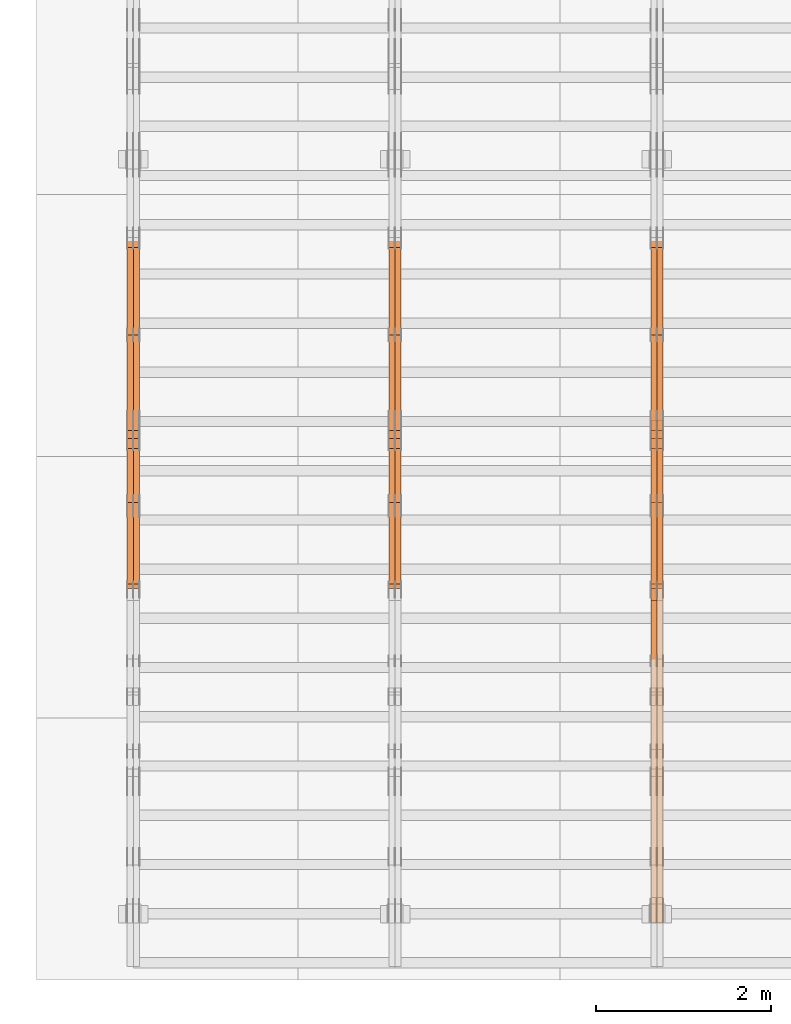
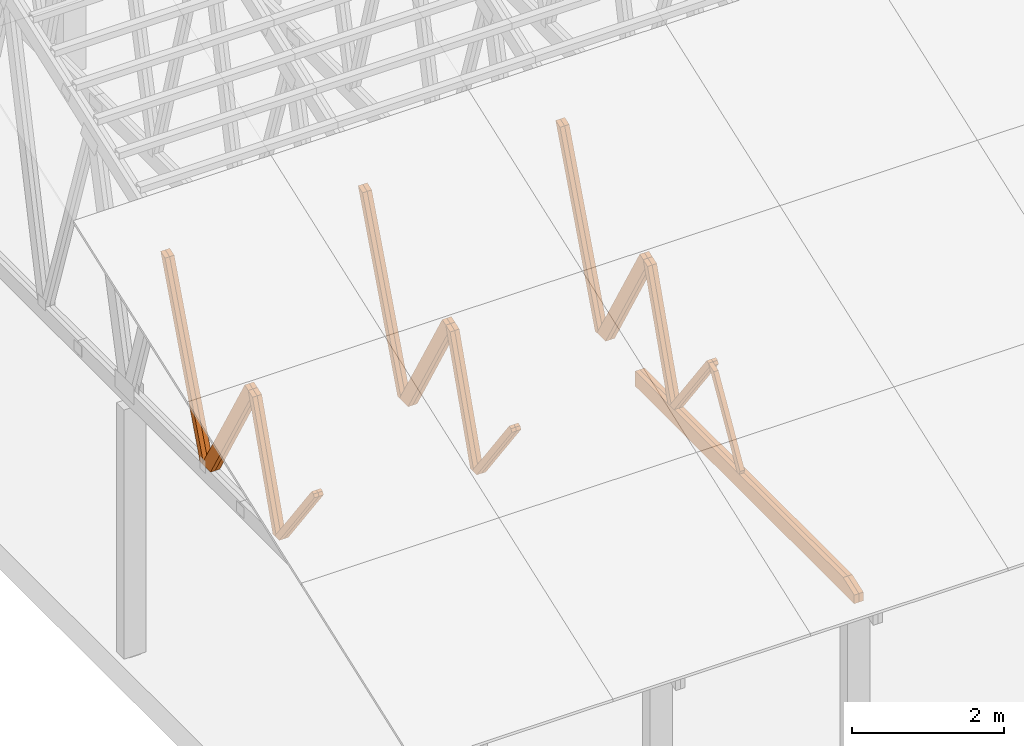
# One storey, part 13 of 189: 27 proxies.
"""IFC2X3 building model written with IfcOpenShell, lengths in millimetres."""

from ifc_helpers import new_model, entity, si_unit, converted_unit, derived_unit, direction, frame, origin, place, context, subcontext, project, spatial, polyline, outline, extrude, source, transform, mapped, material, type_object, type_shapes, element, save


model = new_model("IFC2X3")

# Units and contexts
model_context = context("Model", 3, precision=0.01, world=origin(), true_north=direction((6.12303176911189e-17, 1.0)))
body_context = subcontext(model_context, "Body", "Model", "MODEL_VIEW")
ifc_project = project(units=[si_unit("LENGTHUNIT", "METRE", prefix="MILLI"), si_unit("AREAUNIT", "SQUARE_METRE"), si_unit("VOLUMEUNIT", "CUBIC_METRE"), converted_unit("PLANEANGLEUNIT", "DEGREE", entity("IfcRatioMeasure", 0.0174532925199433), si_unit("PLANEANGLEUNIT", "RADIAN"), dimensions=[0, 0, 0, 0, 0, 0, 0]), si_unit("MASSUNIT", "GRAM", prefix="KILO"), derived_unit("MASSDENSITYUNIT", [(si_unit("MASSUNIT", "GRAM", prefix="KILO"), 1), (si_unit("LENGTHUNIT", "METRE"), -3)]), si_unit("TIMEUNIT", "SECOND"), si_unit("FREQUENCYUNIT", "HERTZ"), si_unit("THERMODYNAMICTEMPERATUREUNIT", "DEGREE_CELSIUS"), derived_unit("THERMALTRANSMITTANCEUNIT", [(si_unit("MASSUNIT", "GRAM", prefix="KILO"), 1), (si_unit("THERMODYNAMICTEMPERATUREUNIT", "KELVIN"), -1), (si_unit("TIMEUNIT", "SECOND"), -3)]), derived_unit("VOLUMETRICFLOWRATEUNIT", [(si_unit("LENGTHUNIT", "METRE"), 3), (si_unit("TIMEUNIT", "SECOND"), -1)]), si_unit("ELECTRICCURRENTUNIT", "AMPERE"), si_unit("ELECTRICVOLTAGEUNIT", "VOLT"), si_unit("POWERUNIT", "WATT"), si_unit("FORCEUNIT", "NEWTON"), si_unit("ILLUMINANCEUNIT", "LUX"), si_unit("LUMINOUSFLUXUNIT", "LUMEN"), si_unit("LUMINOUSINTENSITYUNIT", "CANDELA"), derived_unit("USERDEFINED", [(si_unit("MASSUNIT", "GRAM", prefix="KILO"), -1), (si_unit("LENGTHUNIT", "METRE"), -2), (si_unit("TIMEUNIT", "SECOND"), 3), (si_unit("LUMINOUSFLUXUNIT", "LUMEN"), 1)]), derived_unit("LINEARVELOCITYUNIT", [(si_unit("LENGTHUNIT", "METRE"), 1), (si_unit("TIMEUNIT", "SECOND"), -1)]), si_unit("PRESSUREUNIT", "PASCAL"), derived_unit("USERDEFINED", [(si_unit("LENGTHUNIT", "METRE"), -2), (si_unit("MASSUNIT", "GRAM", prefix="KILO"), 1), (si_unit("TIMEUNIT", "SECOND"), -2)])], contexts=[model_context])

# Site, building, storey
site_placement = place(None, origin())
site = spatial("IfcSite", under=ifc_project, at=site_placement, CompositionType="ELEMENT")
building_placement = place(site_placement, origin())
building = spatial("IfcBuilding", under=site, at=building_placement, CompositionType="ELEMENT")
storey_placement = place(building_placement, origin())
storey = spatial("IfcBuildingStorey", under=building, at=storey_placement, Name="Default", CompositionType="ELEMENT", Elevation=0.0)

# Proxies
ifc_material_1 = material(Name="IfcSurfaceStyle #35470")
building_element_proxy_type_1 = type_object("IfcBuildingElementProxyType", Name="T1-W8 35468", PredefinedType="NOTDEFINED", material=ifc_material_1)
shared_shape_1 = source(origin(), body_context, "Body", "SweptSolid", [
    extrude(outline(polyline([(-1781.70529904483, -47.500320228718), (1161.65050357787, -47.5003202287179), (1179.56135870849, 0.000731866266039397), (1140.6022069428, 47.4998218997103), (-1700.10877018433, 47.5000866914596), (-1781.70529904483, -47.500320228718)])), frame((1179.56135870869, 47.5007236522113, 0.0), z_axis=(0.0, 0.0, 1.0), x_axis=(-1.0, 3.74658825645258e-07, 0.0)), (0.0, 0.0, 1.0), 69.9999999999998),
])
type_shapes(building_element_proxy_type_1, [shared_shape_1])
proxy_1_placement = place(building_placement, frame((6335.0, 6723.5697965901, 261.758864533503), z_axis=(-1.0, 0.0, 0.0), x_axis=(0.0, 0.352814979177603, 0.93569310698963)))
element("IfcBuildingElementProxy", 1, at=proxy_1_placement, inside=storey, type_object=building_element_proxy_type_1, material=ifc_material_1, Name="T1-W8", context=body_context, shape_type="MappedRepresentation", body=[
    mapped(shared_shape_1, transform((0.0, 0.0, 0.0), scale=1.0)),
])
ifc_material_2 = material(Name="IfcSurfaceStyle #35404")
building_element_proxy_type_2 = type_object("IfcBuildingElementProxyType", Name="T1-W8 35402", PredefinedType="NOTDEFINED", material=ifc_material_2)
shared_shape_2 = source(origin(), body_context, "Body", "SweptSolid", [
    extrude(outline(polyline([(-1781.70529904483, -47.500320228718), (1161.65050357787, -47.5003202287179), (1179.56135870849, 0.000731866266039397), (1140.6022069428, 47.4998218997103), (-1700.10877018433, 47.5000866914596), (-1781.70529904483, -47.500320228718)])), frame((1179.56135870869, 47.5007236522113, 0.0), z_axis=(0.0, 0.0, 1.0), x_axis=(-1.0, 3.74658825645258e-07, 0.0)), (0.0, 0.0, 1.0), 69.9999999999998),
])
type_shapes(building_element_proxy_type_2, [shared_shape_2])
proxy_2_placement = place(building_placement, frame((6265.0, 6723.5697965901, 261.758864533503), z_axis=(-1.0, 0.0, 0.0), x_axis=(0.0, 0.352814979177603, 0.93569310698963)))
element("IfcBuildingElementProxy", 2, at=proxy_2_placement, inside=storey, type_object=building_element_proxy_type_2, material=ifc_material_2, Name="T1-W8", context=body_context, shape_type="MappedRepresentation", body=[
    mapped(shared_shape_2, transform((0.0, 0.0, 0.0), scale=1.0)),
])
ifc_material_3 = material(Name="IfcSurfaceStyle #35206")
building_element_proxy_type_3 = type_object("IfcBuildingElementProxyType", Name="T1-W2 35204", PredefinedType="NOTDEFINED", material=ifc_material_3)
shared_shape_3 = source(origin(), body_context, "Body", "SweptSolid", [
    extrude(outline(polyline([(-765.033104991319, -1130.91940266317), (-539.905732758898, -1130.91940266317), (493.678280567457, 660.584515081422), (452.144945212405, 783.697385511457), (359.115611970356, 817.556904733455), (-765.033104991319, -1130.91940266317)])), frame((904.774360566371, 97.5002668805543, 0.0), z_axis=(0.0, 0.0, 1.0), x_axis=(-0.499731715721184, 0.866180242387438, 0.0)), (0.0, 0.0, 1.0), 69.9999999999998),
])
type_shapes(building_element_proxy_type_3, [shared_shape_3])
proxy_3_placement = place(building_placement, frame((6335.0, 5635.28919163287, 2208.3400784451), z_axis=(-1.0, 0.0, 0.0), x_axis=(0.0, 0.5, -0.866025403784439)))
element("IfcBuildingElementProxy", 3, at=proxy_3_placement, inside=storey, type_object=building_element_proxy_type_3, material=ifc_material_3, Name="T1-W2", context=body_context, shape_type="MappedRepresentation", body=[
    mapped(shared_shape_3, transform((0.0, 0.0, 0.0), scale=1.0)),
])
ifc_material_4 = material(Name="IfcSurfaceStyle #35140")
building_element_proxy_type_4 = type_object("IfcBuildingElementProxyType", Name="T1-W2 35138", PredefinedType="NOTDEFINED", material=ifc_material_4)
shared_shape_4 = source(origin(), body_context, "Body", "SweptSolid", [
    extrude(outline(polyline([(-765.033104991319, -1130.91940266317), (-539.905732758898, -1130.91940266317), (493.678280567457, 660.584515081422), (452.144945212405, 783.697385511457), (359.115611970356, 817.556904733455), (-765.033104991319, -1130.91940266317)])), frame((904.774360566371, 97.5002668805543, 0.0), z_axis=(0.0, 0.0, 1.0), x_axis=(-0.499731715721184, 0.866180242387438, 0.0)), (0.0, 0.0, 1.0), 69.9999999999998),
])
type_shapes(building_element_proxy_type_4, [shared_shape_4])
proxy_4_placement = place(building_placement, frame((6265.0, 5635.28919163287, 2208.3400784451), z_axis=(-1.0, 0.0, 0.0), x_axis=(0.0, 0.5, -0.866025403784439)))
element("IfcBuildingElementProxy", 4, at=proxy_4_placement, inside=storey, type_object=building_element_proxy_type_4, material=ifc_material_4, Name="T1-W2", context=body_context, shape_type="MappedRepresentation", body=[
    mapped(shared_shape_4, transform((0.0, 0.0, 0.0), scale=1.0)),
])
ifc_material_5 = material(Name="IfcSurfaceStyle #34942")
building_element_proxy_type_5 = type_object("IfcBuildingElementProxyType", Name="T1-W9 34940", PredefinedType="NOTDEFINED", material=ifc_material_5)
shared_shape_5 = source(origin(), body_context, "Body", "SweptSolid", [
    extrude(outline(polyline([(-1227.3969292634, -47.5000382896404), (793.242467803064, -47.5000382896404), (809.267705296822, 1.0956605530188e-05), (776.329919980315, 47.5000328113376), (-1151.4431638168, 47.5000328113376), (-1227.3969292634, -47.5000382896404)])), frame((809.267705296822, 47.5000328113376, 0.0), z_axis=(0.0, 0.0, 1.0), x_axis=(-1.0, 0.0, 0.0)), (0.0, 0.0, 1.0), 69.9999999999999),
])
type_shapes(building_element_proxy_type_5, [shared_shape_5])
proxy_5_placement = place(building_placement, frame((6335.0, 4809.76380889125, 260.184242613649), z_axis=(-1.0, 0.0, 0.0), x_axis=(0.0, 0.31966811847134, 0.947529574226047)))
element("IfcBuildingElementProxy", 5, at=proxy_5_placement, inside=storey, type_object=building_element_proxy_type_5, material=ifc_material_5, Name="T1-W9", context=body_context, shape_type="MappedRepresentation", body=[
    mapped(shared_shape_5, transform((0.0, 0.0, 0.0), scale=1.0)),
])
ifc_material_6 = material(Name="IfcSurfaceStyle #34876")
building_element_proxy_type_6 = type_object("IfcBuildingElementProxyType", Name="T1-W9 34874", PredefinedType="NOTDEFINED", material=ifc_material_6)
shared_shape_6 = source(origin(), body_context, "Body", "SweptSolid", [
    extrude(outline(polyline([(-1227.3969292634, -47.5000382896404), (793.242467803064, -47.5000382896404), (809.267705296822, 1.0956605530188e-05), (776.329919980315, 47.5000328113376), (-1151.4431638168, 47.5000328113376), (-1227.3969292634, -47.5000382896404)])), frame((809.267705296822, 47.5000328113376, 0.0), z_axis=(0.0, 0.0, 1.0), x_axis=(-1.0, 0.0, 0.0)), (0.0, 0.0, 1.0), 69.9999999999999),
])
type_shapes(building_element_proxy_type_6, [shared_shape_6])
proxy_6_placement = place(building_placement, frame((6265.0, 4809.76380889125, 260.184242613649), z_axis=(-1.0, 0.0, 0.0), x_axis=(0.0, 0.31966811847134, 0.947529574226047)))
element("IfcBuildingElementProxy", 6, at=proxy_6_placement, inside=storey, type_object=building_element_proxy_type_6, material=ifc_material_6, Name="T1-W9", context=body_context, shape_type="MappedRepresentation", body=[
    mapped(shared_shape_6, transform((0.0, 0.0, 0.0), scale=1.0)),
])
ifc_material_7 = material(Name="IfcSurfaceStyle #34678")
building_element_proxy_type_7 = type_object("IfcBuildingElementProxyType", Name="T1-W10 34676", PredefinedType="NOTDEFINED", material=ifc_material_7)
shared_shape_7 = source(origin(), body_context, "Body", "SweptSolid", [
    extrude(outline(polyline([(-922.639472665691, -47.5001890573134), (629.920966338637, -47.5001890573134), (650.067737483374, 0.000694680531158376), (635.89112756682, 47.4998417170478), (-993.240358723139, 47.4998417170478), (-922.639472665691, -47.5001890573134)])), frame((650.068202545693, 47.4999816623145, 0.0), z_axis=(0.0, 0.0, 1.0), x_axis=(-1.0, 0.0, 0.0)), (0.0, 0.0, 1.0), 69.9999999999999),
])
type_shapes(building_element_proxy_type_7, [shared_shape_7])
proxy_7_placement = place(building_placement, frame((6335.0, 3874.56126239818, 1563.95828147518), z_axis=(-1.0, 0.0, 0.0), x_axis=(0.0, 0.596486092002, -0.802623412347398)))
element("IfcBuildingElementProxy", 7, at=proxy_7_placement, inside=storey, type_object=building_element_proxy_type_7, material=ifc_material_7, Name="T1-W10", context=body_context, shape_type="MappedRepresentation", body=[
    mapped(shared_shape_7, transform((0.0, 0.0, 0.0), scale=1.0)),
])
ifc_material_8 = material(Name="IfcSurfaceStyle #34612")
building_element_proxy_type_8 = type_object("IfcBuildingElementProxyType", Name="T1-W10 34610", PredefinedType="NOTDEFINED", material=ifc_material_8)
shared_shape_8 = source(origin(), body_context, "Body", "SweptSolid", [
    extrude(outline(polyline([(-922.639472665691, -47.5001890573134), (629.920966338637, -47.5001890573134), (650.067737483374, 0.000694680531158376), (635.89112756682, 47.4998417170478), (-993.240358723139, 47.4998417170478), (-922.639472665691, -47.5001890573134)])), frame((650.068202545693, 47.4999816623145, 0.0), z_axis=(0.0, 0.0, 1.0), x_axis=(-1.0, 0.0, 0.0)), (0.0, 0.0, 1.0), 69.9999999999999),
])
type_shapes(building_element_proxy_type_8, [shared_shape_8])
proxy_8_placement = place(building_placement, frame((6265.0, 3874.56126239818, 1563.95828147518), z_axis=(-1.0, 0.0, 0.0), x_axis=(0.0, 0.596486092002, -0.802623412347398)))
element("IfcBuildingElementProxy", 8, at=proxy_8_placement, inside=storey, type_object=building_element_proxy_type_8, material=ifc_material_8, Name="T1-W10", context=body_context, shape_type="MappedRepresentation", body=[
    mapped(shared_shape_8, transform((0.0, 0.0, 0.0), scale=1.0)),
])
ifc_material_9 = material(Name="IfcSurfaceStyle #34348")
building_element_proxy_type_9 = type_object("IfcBuildingElementProxyType", Name="T1-W11 34346", PredefinedType="NOTDEFINED", material=ifc_material_9)
shared_shape_9 = source(origin(), body_context, "Body", "SweptSolid", [
    extrude(outline(polyline([(593.358012843793, -552.565239103314), (742.388662259985, -552.565239103314), (-410.498749190676, 401.275038694583), (-462.246133468927, 382.44069706518), (-463.001792444175, 321.414742446865), (593.358012843793, -552.565239103314)])), frame((599.94412413079, 47.5003788877286, 0.0), z_axis=(0.0, 0.0, 1.0), x_axis=(0.770483455324544, 0.637459994879013, 0.0)), (0.0, 0.0, 1.0), 69.9999999999999),
])
type_shapes(building_element_proxy_type_9, [shared_shape_9])
proxy_9_placement = place(building_placement, frame((6265.0, 2983.26655629375, 269.034992751429), z_axis=(-1.0, 0.0, 0.0), x_axis=(0.0, 0.505995901100606, 0.862535882192379)))
element("IfcBuildingElementProxy", 9, at=proxy_9_placement, inside=storey, type_object=building_element_proxy_type_9, material=ifc_material_9, Name="T1-W11", context=body_context, shape_type="MappedRepresentation", body=[
    mapped(shared_shape_9, transform((0.0, 0.0, 0.0), scale=1.0)),
])
ifc_material_10 = material(Name="IfcSurfaceStyle #32542")
building_element_proxy_type_10 = type_object("IfcBuildingElementProxyType", Name="T1-B2 32540", PredefinedType="NOTDEFINED", material=ifc_material_10)
shared_shape_10 = source(origin(), body_context, "Body", "SweptSolid", [
    extrude(outline(polyline([(-3399.385546875, -125.855288696291), (2363.08125, -125.855288696291), (2363.08125, 13.4211547851572), (2072.60859375, 119.144711303712), (-3399.385546875, 119.144711303712), (-3399.385546875, -125.855288696291)])), frame((2363.08125, 119.144711303712, 0.0), z_axis=(0.0, 0.0, 1.0), x_axis=(-1.0, 0.0, 0.0)), (0.0, 0.0, 1.0), 69.9999999999997),
])
type_shapes(building_element_proxy_type_10, [shared_shape_10])
proxy_10_placement = place(building_placement, frame((6335.0, 0.0, 245.0), z_axis=(-1.0, 0.0, 0.0), x_axis=(0.0, 1.0, 0.0)))
element("IfcBuildingElementProxy", 10, at=proxy_10_placement, inside=storey, type_object=building_element_proxy_type_10, material=ifc_material_10, Name="T1-B2", context=body_context, shape_type="MappedRepresentation", body=[
    mapped(shared_shape_10, transform((0.0, 0.0, 0.0), scale=1.0)),
])
ifc_material_11 = material(Name="IfcSurfaceStyle #32476")
building_element_proxy_type_11 = type_object("IfcBuildingElementProxyType", Name="T1-B2 32474", PredefinedType="NOTDEFINED", material=ifc_material_11)
shared_shape_11 = source(origin(), body_context, "Body", "SweptSolid", [
    extrude(outline(polyline([(-3399.385546875, -125.855288696291), (2363.08125, -125.855288696291), (2363.08125, 13.4211547851572), (2072.60859375, 119.144711303712), (-3399.385546875, 119.144711303712), (-3399.385546875, -125.855288696291)])), frame((2363.08125, 119.144711303712, 0.0), z_axis=(0.0, 0.0, 1.0), x_axis=(-1.0, 0.0, 0.0)), (0.0, 0.0, 1.0), 69.9999999999997),
])
type_shapes(building_element_proxy_type_11, [shared_shape_11])
proxy_11_placement = place(building_placement, frame((6265.0, 0.0, 245.0), z_axis=(-1.0, 0.0, 0.0), x_axis=(0.0, 1.0, 0.0)))
element("IfcBuildingElementProxy", 11, at=proxy_11_placement, inside=storey, type_object=building_element_proxy_type_11, material=ifc_material_11, Name="T1-B2", context=body_context, shape_type="MappedRepresentation", body=[
    mapped(shared_shape_11, transform((0.0, 0.0, 0.0), scale=1.0)),
])
ifc_material_12 = material(Name="IfcSurfaceStyle #19680")
building_element_proxy_type_12 = type_object("IfcBuildingElementProxyType", Name="T1-W8 19678", PredefinedType="NOTDEFINED", material=ifc_material_12)
shared_shape_12 = source(origin(), body_context, "Body", "SweptSolid", [
    extrude(outline(polyline([(-1781.70529904483, -47.500320228718), (1161.65050357787, -47.5003202287179), (1179.56135870849, 0.000731866266039397), (1140.6022069428, 47.4998218997103), (-1700.10877018433, 47.5000866914596), (-1781.70529904483, -47.500320228718)])), frame((1179.56135870869, 47.5007236522113, 0.0), z_axis=(0.0, 0.0, 1.0), x_axis=(-1.0, 3.74658825645258e-07, 0.0)), (0.0, 0.0, 1.0), 69.9999999999998),
])
type_shapes(building_element_proxy_type_12, [shared_shape_12])
proxy_12_placement = place(building_placement, frame((3335.0, 6723.5697965901, 261.758864533503), z_axis=(-1.0, 0.0, 0.0), x_axis=(0.0, 0.352814979177603, 0.93569310698963)))
element("IfcBuildingElementProxy", 12, at=proxy_12_placement, inside=storey, type_object=building_element_proxy_type_12, material=ifc_material_12, Name="T1-W8", context=body_context, shape_type="MappedRepresentation", body=[
    mapped(shared_shape_12, transform((0.0, 0.0, 0.0), scale=1.0)),
])
ifc_material_13 = material(Name="IfcSurfaceStyle #19614")
building_element_proxy_type_13 = type_object("IfcBuildingElementProxyType", Name="T1-W8 19612", PredefinedType="NOTDEFINED", material=ifc_material_13)
shared_shape_13 = source(origin(), body_context, "Body", "SweptSolid", [
    extrude(outline(polyline([(-1781.70529904483, -47.500320228718), (1161.65050357787, -47.5003202287179), (1179.56135870849, 0.000731866266039397), (1140.6022069428, 47.4998218997103), (-1700.10877018433, 47.5000866914596), (-1781.70529904483, -47.500320228718)])), frame((1179.56135870869, 47.5007236522113, 0.0), z_axis=(0.0, 0.0, 1.0), x_axis=(-1.0, 3.74658825645258e-07, 0.0)), (0.0, 0.0, 1.0), 69.9999999999998),
])
type_shapes(building_element_proxy_type_13, [shared_shape_13])
proxy_13_placement = place(building_placement, frame((3265.0, 6723.5697965901, 261.758864533503), z_axis=(-1.0, 0.0, 0.0), x_axis=(0.0, 0.352814979177603, 0.93569310698963)))
element("IfcBuildingElementProxy", 13, at=proxy_13_placement, inside=storey, type_object=building_element_proxy_type_13, material=ifc_material_13, Name="T1-W8", context=body_context, shape_type="MappedRepresentation", body=[
    mapped(shared_shape_13, transform((0.0, 0.0, 0.0), scale=1.0)),
])
ifc_material_14 = material(Name="IfcSurfaceStyle #19416")
building_element_proxy_type_14 = type_object("IfcBuildingElementProxyType", Name="T1-W2 19414", PredefinedType="NOTDEFINED", material=ifc_material_14)
shared_shape_14 = source(origin(), body_context, "Body", "SweptSolid", [
    extrude(outline(polyline([(-765.033104991319, -1130.91940266317), (-539.905732758898, -1130.91940266317), (493.678280567457, 660.584515081422), (452.144945212405, 783.697385511457), (359.115611970356, 817.556904733455), (-765.033104991319, -1130.91940266317)])), frame((904.774360566371, 97.5002668805543, 0.0), z_axis=(0.0, 0.0, 1.0), x_axis=(-0.499731715721184, 0.866180242387438, 0.0)), (0.0, 0.0, 1.0), 69.9999999999998),
])
type_shapes(building_element_proxy_type_14, [shared_shape_14])
proxy_14_placement = place(building_placement, frame((3335.0, 5635.28919163287, 2208.3400784451), z_axis=(-1.0, 0.0, 0.0), x_axis=(0.0, 0.5, -0.866025403784439)))
element("IfcBuildingElementProxy", 14, at=proxy_14_placement, inside=storey, type_object=building_element_proxy_type_14, material=ifc_material_14, Name="T1-W2", context=body_context, shape_type="MappedRepresentation", body=[
    mapped(shared_shape_14, transform((0.0, 0.0, 0.0), scale=1.0)),
])
ifc_material_15 = material(Name="IfcSurfaceStyle #19350")
building_element_proxy_type_15 = type_object("IfcBuildingElementProxyType", Name="T1-W2 19348", PredefinedType="NOTDEFINED", material=ifc_material_15)
shared_shape_15 = source(origin(), body_context, "Body", "SweptSolid", [
    extrude(outline(polyline([(-765.033104991319, -1130.91940266317), (-539.905732758898, -1130.91940266317), (493.678280567457, 660.584515081422), (452.144945212405, 783.697385511457), (359.115611970356, 817.556904733455), (-765.033104991319, -1130.91940266317)])), frame((904.774360566371, 97.5002668805543, 0.0), z_axis=(0.0, 0.0, 1.0), x_axis=(-0.499731715721184, 0.866180242387438, 0.0)), (0.0, 0.0, 1.0), 69.9999999999998),
])
type_shapes(building_element_proxy_type_15, [shared_shape_15])
proxy_15_placement = place(building_placement, frame((3265.0, 5635.28919163287, 2208.3400784451), z_axis=(-1.0, 0.0, 0.0), x_axis=(0.0, 0.5, -0.866025403784439)))
element("IfcBuildingElementProxy", 15, at=proxy_15_placement, inside=storey, type_object=building_element_proxy_type_15, material=ifc_material_15, Name="T1-W2", context=body_context, shape_type="MappedRepresentation", body=[
    mapped(shared_shape_15, transform((0.0, 0.0, 0.0), scale=1.0)),
])
ifc_material_16 = material(Name="IfcSurfaceStyle #19152")
building_element_proxy_type_16 = type_object("IfcBuildingElementProxyType", Name="T1-W9 19150", PredefinedType="NOTDEFINED", material=ifc_material_16)
shared_shape_16 = source(origin(), body_context, "Body", "SweptSolid", [
    extrude(outline(polyline([(-1227.3969292634, -47.5000382896404), (793.242467803064, -47.5000382896404), (809.267705296822, 1.0956605530188e-05), (776.329919980315, 47.5000328113376), (-1151.4431638168, 47.5000328113376), (-1227.3969292634, -47.5000382896404)])), frame((809.267705296822, 47.5000328113376, 0.0), z_axis=(0.0, 0.0, 1.0), x_axis=(-1.0, 0.0, 0.0)), (0.0, 0.0, 1.0), 69.9999999999999),
])
type_shapes(building_element_proxy_type_16, [shared_shape_16])
proxy_16_placement = place(building_placement, frame((3335.0, 4809.76380889125, 260.184242613649), z_axis=(-1.0, 0.0, 0.0), x_axis=(0.0, 0.31966811847134, 0.947529574226047)))
element("IfcBuildingElementProxy", 16, at=proxy_16_placement, inside=storey, type_object=building_element_proxy_type_16, material=ifc_material_16, Name="T1-W9", context=body_context, shape_type="MappedRepresentation", body=[
    mapped(shared_shape_16, transform((0.0, 0.0, 0.0), scale=1.0)),
])
ifc_material_17 = material(Name="IfcSurfaceStyle #19086")
building_element_proxy_type_17 = type_object("IfcBuildingElementProxyType", Name="T1-W9 19084", PredefinedType="NOTDEFINED", material=ifc_material_17)
shared_shape_17 = source(origin(), body_context, "Body", "SweptSolid", [
    extrude(outline(polyline([(-1227.3969292634, -47.5000382896404), (793.242467803064, -47.5000382896404), (809.267705296822, 1.0956605530188e-05), (776.329919980315, 47.5000328113376), (-1151.4431638168, 47.5000328113376), (-1227.3969292634, -47.5000382896404)])), frame((809.267705296822, 47.5000328113376, 0.0), z_axis=(0.0, 0.0, 1.0), x_axis=(-1.0, 0.0, 0.0)), (0.0, 0.0, 1.0), 69.9999999999999),
])
type_shapes(building_element_proxy_type_17, [shared_shape_17])
proxy_17_placement = place(building_placement, frame((3265.0, 4809.76380889125, 260.184242613649), z_axis=(-1.0, 0.0, 0.0), x_axis=(0.0, 0.31966811847134, 0.947529574226047)))
element("IfcBuildingElementProxy", 17, at=proxy_17_placement, inside=storey, type_object=building_element_proxy_type_17, material=ifc_material_17, Name="T1-W9", context=body_context, shape_type="MappedRepresentation", body=[
    mapped(shared_shape_17, transform((0.0, 0.0, 0.0), scale=1.0)),
])
ifc_material_18 = material(Name="IfcSurfaceStyle #18888")
building_element_proxy_type_18 = type_object("IfcBuildingElementProxyType", Name="T1-W10 18886", PredefinedType="NOTDEFINED", material=ifc_material_18)
shared_shape_18 = source(origin(), body_context, "Body", "SweptSolid", [
    extrude(outline(polyline([(-922.639472665691, -47.5001890573134), (629.920966338637, -47.5001890573134), (650.067737483374, 0.000694680531158376), (635.89112756682, 47.4998417170478), (-993.240358723139, 47.4998417170478), (-922.639472665691, -47.5001890573134)])), frame((650.068202545693, 47.4999816623145, 0.0), z_axis=(0.0, 0.0, 1.0), x_axis=(-1.0, 0.0, 0.0)), (0.0, 0.0, 1.0), 69.9999999999999),
])
type_shapes(building_element_proxy_type_18, [shared_shape_18])
proxy_18_placement = place(building_placement, frame((3335.0, 3874.56126239818, 1563.95828147518), z_axis=(-1.0, 0.0, 0.0), x_axis=(0.0, 0.596486092002, -0.802623412347398)))
element("IfcBuildingElementProxy", 18, at=proxy_18_placement, inside=storey, type_object=building_element_proxy_type_18, material=ifc_material_18, Name="T1-W10", context=body_context, shape_type="MappedRepresentation", body=[
    mapped(shared_shape_18, transform((0.0, 0.0, 0.0), scale=1.0)),
])
ifc_material_19 = material(Name="IfcSurfaceStyle #18822")
building_element_proxy_type_19 = type_object("IfcBuildingElementProxyType", Name="T1-W10 18820", PredefinedType="NOTDEFINED", material=ifc_material_19)
shared_shape_19 = source(origin(), body_context, "Body", "SweptSolid", [
    extrude(outline(polyline([(-922.639472665691, -47.5001890573134), (629.920966338637, -47.5001890573134), (650.067737483374, 0.000694680531158376), (635.89112756682, 47.4998417170478), (-993.240358723139, 47.4998417170478), (-922.639472665691, -47.5001890573134)])), frame((650.068202545693, 47.4999816623145, 0.0), z_axis=(0.0, 0.0, 1.0), x_axis=(-1.0, 0.0, 0.0)), (0.0, 0.0, 1.0), 69.9999999999999),
])
type_shapes(building_element_proxy_type_19, [shared_shape_19])
proxy_19_placement = place(building_placement, frame((3265.0, 3874.56126239818, 1563.95828147518), z_axis=(-1.0, 0.0, 0.0), x_axis=(0.0, 0.596486092002, -0.802623412347398)))
element("IfcBuildingElementProxy", 19, at=proxy_19_placement, inside=storey, type_object=building_element_proxy_type_19, material=ifc_material_19, Name="T1-W10", context=body_context, shape_type="MappedRepresentation", body=[
    mapped(shared_shape_19, transform((0.0, 0.0, 0.0), scale=1.0)),
])
ifc_material_20 = material(Name="IfcSurfaceStyle #3887")
building_element_proxy_type_20 = type_object("IfcBuildingElementProxyType", Name="T1-W8 3885", PredefinedType="NOTDEFINED", material=ifc_material_20)
shared_shape_20 = source(origin(), body_context, "Body", "SweptSolid", [
    extrude(outline(polyline([(-1781.70529904483, -47.500320228718), (1161.65050357787, -47.5003202287179), (1179.56135870849, 0.000731866266039397), (1140.6022069428, 47.4998218997103), (-1700.10877018433, 47.5000866914596), (-1781.70529904483, -47.500320228718)])), frame((1179.56135870869, 47.5007236522113, 0.0), z_axis=(0.0, 0.0, 1.0), x_axis=(-1.0, 3.74658825645258e-07, 0.0)), (0.0, 0.0, 1.0), 69.9999999999998),
])
type_shapes(building_element_proxy_type_20, [shared_shape_20])
proxy_20_placement = place(building_placement, frame((335.0, 6723.5697965901, 261.758864533503), z_axis=(-1.0, 0.0, 0.0), x_axis=(0.0, 0.352814979177603, 0.93569310698963)))
element("IfcBuildingElementProxy", 20, at=proxy_20_placement, inside=storey, type_object=building_element_proxy_type_20, material=ifc_material_20, Name="T1-W8", context=body_context, shape_type="MappedRepresentation", body=[
    mapped(shared_shape_20, transform((0.0, 0.0, 0.0), scale=1.0)),
])
ifc_material_21 = material(Name="IfcSurfaceStyle #3821")
building_element_proxy_type_21 = type_object("IfcBuildingElementProxyType", Name="T1-W8 3819", PredefinedType="NOTDEFINED", material=ifc_material_21)
shared_shape_21 = source(origin(), body_context, "Body", "SweptSolid", [
    extrude(outline(polyline([(-1781.70529904483, -47.500320228718), (1161.65050357787, -47.5003202287179), (1179.56135870849, 0.000731866266039397), (1140.6022069428, 47.4998218997103), (-1700.10877018433, 47.5000866914596), (-1781.70529904483, -47.500320228718)])), frame((1179.56135870869, 47.5007236522113, 0.0), z_axis=(0.0, 0.0, 1.0), x_axis=(-1.0, 3.74658825645258e-07, 0.0)), (0.0, 0.0, 1.0), 69.9999999999998),
])
type_shapes(building_element_proxy_type_21, [shared_shape_21])
proxy_21_placement = place(building_placement, frame((265.0, 6723.5697965901, 261.758864533503), z_axis=(-1.0, 0.0, 0.0), x_axis=(0.0, 0.352814979177603, 0.93569310698963)))
element("IfcBuildingElementProxy", 21, at=proxy_21_placement, inside=storey, type_object=building_element_proxy_type_21, material=ifc_material_21, Name="T1-W8", context=body_context, shape_type="MappedRepresentation", body=[
    mapped(shared_shape_21, transform((0.0, 0.0, 0.0), scale=1.0)),
])
ifc_material_22 = material(Name="IfcSurfaceStyle #3623")
building_element_proxy_type_22 = type_object("IfcBuildingElementProxyType", Name="T1-W2 3621", PredefinedType="NOTDEFINED", material=ifc_material_22)
shared_shape_22 = source(origin(), body_context, "Body", "SweptSolid", [
    extrude(outline(polyline([(-765.033104991319, -1130.91940266317), (-539.905732758898, -1130.91940266317), (493.678280567457, 660.584515081422), (452.144945212405, 783.697385511457), (359.115611970356, 817.556904733455), (-765.033104991319, -1130.91940266317)])), frame((904.774360566371, 97.5002668805543, 0.0), z_axis=(0.0, 0.0, 1.0), x_axis=(-0.499731715721184, 0.866180242387438, 0.0)), (0.0, 0.0, 1.0), 69.9999999999998),
])
type_shapes(building_element_proxy_type_22, [shared_shape_22])
proxy_22_placement = place(building_placement, frame((335.0, 5635.28919163287, 2208.3400784451), z_axis=(-1.0, 0.0, 0.0), x_axis=(0.0, 0.5, -0.866025403784439)))
element("IfcBuildingElementProxy", 22, at=proxy_22_placement, inside=storey, type_object=building_element_proxy_type_22, material=ifc_material_22, Name="T1-W2", context=body_context, shape_type="MappedRepresentation", body=[
    mapped(shared_shape_22, transform((0.0, 0.0, 0.0), scale=1.0)),
])
ifc_material_23 = material(Name="IfcSurfaceStyle #3557")
building_element_proxy_type_23 = type_object("IfcBuildingElementProxyType", Name="T1-W2 3555", PredefinedType="NOTDEFINED", material=ifc_material_23)
shared_shape_23 = source(origin(), body_context, "Body", "SweptSolid", [
    extrude(outline(polyline([(-765.033104991319, -1130.91940266317), (-539.905732758898, -1130.91940266317), (493.678280567457, 660.584515081422), (452.144945212405, 783.697385511457), (359.115611970356, 817.556904733455), (-765.033104991319, -1130.91940266317)])), frame((904.774360566371, 97.5002668805543, 0.0), z_axis=(0.0, 0.0, 1.0), x_axis=(-0.499731715721184, 0.866180242387438, 0.0)), (0.0, 0.0, 1.0), 69.9999999999998),
])
type_shapes(building_element_proxy_type_23, [shared_shape_23])
proxy_23_placement = place(building_placement, frame((265.0, 5635.28919163287, 2208.3400784451), z_axis=(-1.0, 0.0, 0.0), x_axis=(0.0, 0.5, -0.866025403784439)))
element("IfcBuildingElementProxy", 23, at=proxy_23_placement, inside=storey, type_object=building_element_proxy_type_23, material=ifc_material_23, Name="T1-W2", context=body_context, shape_type="MappedRepresentation", body=[
    mapped(shared_shape_23, transform((0.0, 0.0, 0.0), scale=1.0)),
])
ifc_material_24 = material(Name="IfcSurfaceStyle #3359")
building_element_proxy_type_24 = type_object("IfcBuildingElementProxyType", Name="T1-W9 3357", PredefinedType="NOTDEFINED", material=ifc_material_24)
shared_shape_24 = source(origin(), body_context, "Body", "SweptSolid", [
    extrude(outline(polyline([(-1227.3969292634, -47.5000382896404), (793.242467803064, -47.5000382896404), (809.267705296822, 1.0956605530188e-05), (776.329919980315, 47.5000328113376), (-1151.4431638168, 47.5000328113376), (-1227.3969292634, -47.5000382896404)])), frame((809.267705296822, 47.5000328113376, 0.0), z_axis=(0.0, 0.0, 1.0), x_axis=(-1.0, 0.0, 0.0)), (0.0, 0.0, 1.0), 69.9999999999999),
])
type_shapes(building_element_proxy_type_24, [shared_shape_24])
proxy_24_placement = place(building_placement, frame((335.0, 4809.76380889125, 260.184242613649), z_axis=(-1.0, 0.0, 0.0), x_axis=(0.0, 0.31966811847134, 0.947529574226047)))
element("IfcBuildingElementProxy", 24, at=proxy_24_placement, inside=storey, type_object=building_element_proxy_type_24, material=ifc_material_24, Name="T1-W9", context=body_context, shape_type="MappedRepresentation", body=[
    mapped(shared_shape_24, transform((0.0, 0.0, 0.0), scale=1.0)),
])
ifc_material_25 = material(Name="IfcSurfaceStyle #3293")
building_element_proxy_type_25 = type_object("IfcBuildingElementProxyType", Name="T1-W9 3291", PredefinedType="NOTDEFINED", material=ifc_material_25)
shared_shape_25 = source(origin(), body_context, "Body", "SweptSolid", [
    extrude(outline(polyline([(-1227.3969292634, -47.5000382896404), (793.242467803064, -47.5000382896404), (809.267705296822, 1.0956605530188e-05), (776.329919980315, 47.5000328113376), (-1151.4431638168, 47.5000328113376), (-1227.3969292634, -47.5000382896404)])), frame((809.267705296822, 47.5000328113376, 0.0), z_axis=(0.0, 0.0, 1.0), x_axis=(-1.0, 0.0, 0.0)), (0.0, 0.0, 1.0), 69.9999999999999),
])
type_shapes(building_element_proxy_type_25, [shared_shape_25])
proxy_25_placement = place(building_placement, frame((265.0, 4809.76380889125, 260.184242613649), z_axis=(-1.0, 0.0, 0.0), x_axis=(0.0, 0.31966811847134, 0.947529574226047)))
element("IfcBuildingElementProxy", 25, at=proxy_25_placement, inside=storey, type_object=building_element_proxy_type_25, material=ifc_material_25, Name="T1-W9", context=body_context, shape_type="MappedRepresentation", body=[
    mapped(shared_shape_25, transform((0.0, 0.0, 0.0), scale=1.0)),
])
ifc_material_26 = material(Name="IfcSurfaceStyle #3095")
building_element_proxy_type_26 = type_object("IfcBuildingElementProxyType", Name="T1-W10 3093", PredefinedType="NOTDEFINED", material=ifc_material_26)
shared_shape_26 = source(origin(), body_context, "Body", "SweptSolid", [
    extrude(outline(polyline([(-922.639472665691, -47.5001890573134), (629.920966338637, -47.5001890573134), (650.067737483374, 0.000694680531158376), (635.89112756682, 47.4998417170478), (-993.240358723139, 47.4998417170478), (-922.639472665691, -47.5001890573134)])), frame((650.068202545693, 47.4999816623145, 0.0), z_axis=(0.0, 0.0, 1.0), x_axis=(-1.0, 0.0, 0.0)), (0.0, 0.0, 1.0), 69.9999999999999),
])
type_shapes(building_element_proxy_type_26, [shared_shape_26])
proxy_26_placement = place(building_placement, frame((335.0, 3874.56126239818, 1563.95828147518), z_axis=(-1.0, 0.0, 0.0), x_axis=(0.0, 0.596486092002, -0.802623412347398)))
element("IfcBuildingElementProxy", 26, at=proxy_26_placement, inside=storey, type_object=building_element_proxy_type_26, material=ifc_material_26, Name="T1-W10", context=body_context, shape_type="MappedRepresentation", body=[
    mapped(shared_shape_26, transform((0.0, 0.0, 0.0), scale=1.0)),
])
ifc_material_27 = material(Name="IfcSurfaceStyle #3029")
building_element_proxy_type_27 = type_object("IfcBuildingElementProxyType", Name="T1-W10 3027", PredefinedType="NOTDEFINED", material=ifc_material_27)
shared_shape_27 = source(origin(), body_context, "Body", "SweptSolid", [
    extrude(outline(polyline([(-922.639472665691, -47.5001890573134), (629.920966338637, -47.5001890573134), (650.067737483374, 0.000694680531158376), (635.89112756682, 47.4998417170478), (-993.240358723139, 47.4998417170478), (-922.639472665691, -47.5001890573134)])), frame((650.068202545693, 47.4999816623145, 0.0), z_axis=(0.0, 0.0, 1.0), x_axis=(-1.0, 0.0, 0.0)), (0.0, 0.0, 1.0), 69.9999999999999),
])
type_shapes(building_element_proxy_type_27, [shared_shape_27])
proxy_27_placement = place(building_placement, frame((265.0, 3874.56126239818, 1563.95828147518), z_axis=(-1.0, 0.0, 0.0), x_axis=(0.0, 0.596486092002, -0.802623412347398)))
element("IfcBuildingElementProxy", 27, at=proxy_27_placement, inside=storey, type_object=building_element_proxy_type_27, material=ifc_material_27, Name="T1-W10", context=body_context, shape_type="MappedRepresentation", body=[
    mapped(shared_shape_27, transform((0.0, 0.0, 0.0), scale=1.0)),
])

save(model, "model.ifc")
